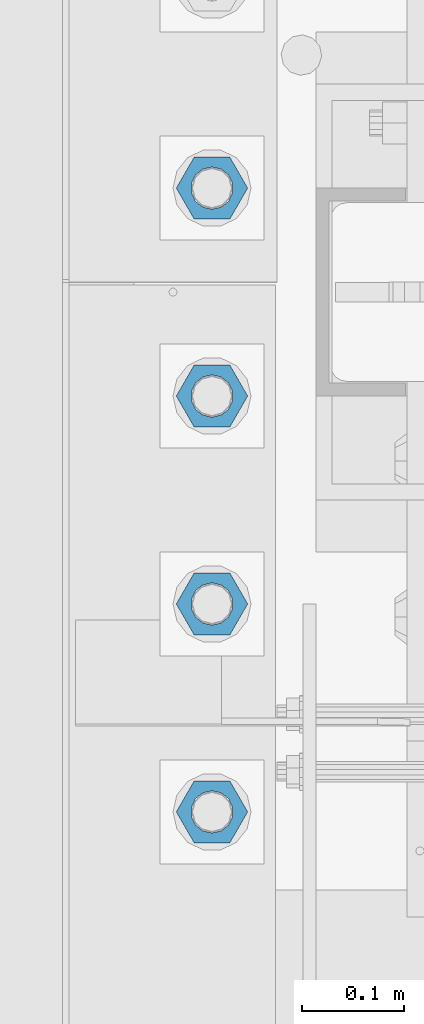
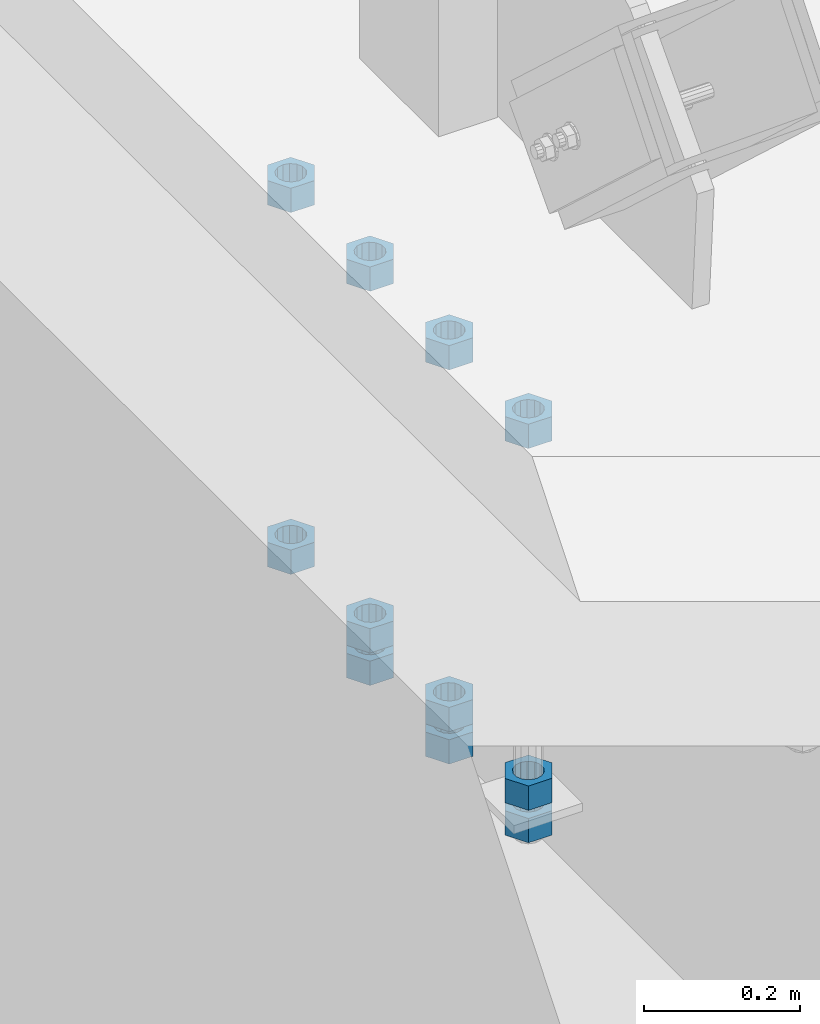
# One storey, part 984 of 1763: 11 columns, 1 element without a shape of its own.
"""IFC2X3 building model written with IfcOpenShell, lengths in millimetres."""

from ifc_helpers import new_model, si_unit, frame, origin_with_axes, place, context, subcontext, project, spatial, faceted_brep, material, type_object, element, aggregate, save


model = new_model("IFC2X3")

# Units and contexts
model_context = context("Model", 3, precision=1e-05, world=origin_with_axes())
body_context = subcontext(model_context, "Body", "Model", "MODEL_VIEW")
ifc_project = project(units=[si_unit("LENGTHUNIT", "METRE", prefix="MILLI"), si_unit("AREAUNIT", "SQUARE_METRE"), si_unit("VOLUMEUNIT", "CUBIC_METRE"), si_unit("MASSUNIT", "GRAM", prefix="KILO"), si_unit("TIMEUNIT", "SECOND"), si_unit("PLANEANGLEUNIT", "RADIAN"), si_unit("SOLIDANGLEUNIT", "STERADIAN"), si_unit("THERMODYNAMICTEMPERATUREUNIT", "DEGREE_CELSIUS"), si_unit("LUMINOUSINTENSITYUNIT", "LUMEN")], contexts=[model_context])

# Site, building, storey
site_placement = place(None, origin_with_axes())
site = spatial("IfcSite", under=ifc_project, at=site_placement, CompositionType="ELEMENT")
building_placement = place(site_placement, origin_with_axes())
building = spatial("IfcBuilding", under=site, at=building_placement, Name="Undefined", CompositionType="ELEMENT")
storey_placement = place(building_placement, origin_with_axes())
storey = spatial("IfcBuildingStorey", under=building, at=storey_placement, Name="Undefined", CompositionType="ELEMENT", Elevation=0.0)

# Assembly, columns
assembly_placement = place(storey_placement, origin_with_axes())
assembly = element("IfcElementAssembly", 1, at=assembly_placement, inside=storey, Name="TEMPLATE", AssemblyPlace="NOTDEFINED", PredefinedType="RIGID_FRAME")
ifc_material = material(Name="STEEL/A563")
column_type = type_object("IfcColumnType", Name="1-1/2_HEAVY_HEX_NUT", PredefinedType="NOTDEFINED")
column_1_placement = place(assembly_placement, frame((-87578.6372736983, -50.7999999999992, 5189.5375), z_axis=(0.0, -1.0, 0.0), x_axis=(0.0, 0.0, -1.0)))
column_1 = element("IfcColumn", 2, at=column_1_placement, type_object=column_type, material=ifc_material, Name="NUT", ObjectType="1-1/2_HEAVY_HEX_NUT", context=body_context, shape_type="Brep", body=[
    faceted_brep([(0.0, -34.9199981689453, 0.0), (0.0, -17.4599990844727, -30.25), (38.1000000000004, -17.4599990844727, -30.25), (38.1000000000004, -34.9199981689453, 0.0), (0.0, 17.4599990844727, -30.25), (38.1000000000004, 17.4599990844727, -30.25), (0.0, 34.9199981689453, 0.0), (38.1000000000004, 34.9199981689453, 0.0), (0.0, 17.4599990844727, 30.25), (38.1000000000004, 17.4599990844727, 30.25), (0.0, -17.4599990844727, 30.25), (38.1000000000004, -17.4599990844727, 30.25), (0.0, 0.0, 20.6399993896484), (0.0, 8.95536011056538, 18.5959968835978), (38.1000000000004, 8.95536011056538, 18.5959968835978), (38.1000000000004, 0.0, 20.6399993896484), (0.0, 16.1370013209453, 12.8688291298167), (38.1000000000004, 16.1370013209453, 12.8688291298167), (0.0, 20.1225115123816, 4.59283194104137), (38.1000000000004, 20.1225115123816, 4.59283194104137), (0.0, 20.1225115123816, -4.59283194104319), (38.1000000000004, 20.1225115123816, -4.59283194104319), (0.0, 16.1370013209453, -12.8688291298167), (38.1000000000004, 16.1370013209453, -12.8688291298167), (0.0, 8.95536011056538, -18.5959968835978), (38.1000000000004, 8.95536011056538, -18.5959968835978), (0.0, 0.0, -20.6399993896484), (38.1000000000004, 0.0, -20.6399993896484), (0.0, -8.95536011056538, -18.5959968835978), (38.1000000000004, -8.95536011056538, -18.5959968835978), (0.0, -16.1370013209453, -12.8688291298167), (38.1000000000004, -16.1370013209453, -12.8688291298167), (0.0, -20.1225115123816, -4.59283194104137), (38.1000000000004, -20.1225115123816, -4.59283194104137), (0.0, -20.1225115123816, 4.59283194104319), (38.1000000000004, -20.1225115123816, 4.59283194104319), (0.0, -16.1370013209453, 12.8688291298167), (38.1000000000004, -16.1370013209453, 12.8688291298167), (0.0, -8.95536011056538, 18.5959968835978), (38.1000000000004, -8.95536011056538, 18.5959968835978)], [[[0, 1, 2, 3]], [[1, 4, 5, 2]], [[4, 6, 7, 5]], [[6, 8, 9, 7]], [[8, 10, 11, 9]], [[10, 0, 3, 11]], [[12, 13, 14, 15]], [[13, 16, 17, 14]], [[16, 18, 19, 17]], [[18, 20, 21, 19]], [[20, 22, 23, 21]], [[22, 24, 25, 23]], [[24, 26, 27, 25]], [[26, 28, 29, 27]], [[28, 30, 31, 29]], [[30, 32, 33, 31]], [[32, 34, 35, 33]], [[34, 36, 37, 35]], [[36, 38, 39, 37]], [[38, 12, 15, 39]], [[5, 7, 9, 11, 3, 2], [17, 19, 21, 23, 25, 27, 29, 31, 33, 35, 37, 39, 15, 14]], [[10, 8, 6, 4, 1, 0], [38, 36, 34, 32, 30, 28, 26, 24, 22, 20, 18, 16, 13, 12]]]),
])
column_2_placement = place(assembly_placement, frame((-87578.6372736983, -50.7999999999992, 4622.8), z_axis=(0.0, -1.0, 0.0), x_axis=(0.0, 0.0, -1.0)))
column_2 = element("IfcColumn", 3, at=column_2_placement, type_object=column_type, material=ifc_material, Name="NUT", ObjectType="1-1/2_HEAVY_HEX_NUT", context=body_context, shape_type="Brep", body=[
    faceted_brep([(0.0, -34.9199981689453, 0.0), (0.0, -17.4599990844727, -30.25), (38.1000000000004, -17.4599990844727, -30.25), (38.1000000000004, -34.9199981689453, 0.0), (0.0, 17.4599990844727, -30.25), (38.1000000000004, 17.4599990844727, -30.25), (0.0, 34.9199981689453, 0.0), (38.1000000000004, 34.9199981689453, 0.0), (0.0, 17.4599990844727, 30.25), (38.1000000000004, 17.4599990844727, 30.25), (0.0, -17.4599990844727, 30.25), (38.1000000000004, -17.4599990844727, 30.25), (0.0, 0.0, 20.6399993896484), (0.0, 8.95536011056538, 18.5959968835978), (38.1000000000004, 8.95536011056538, 18.5959968835978), (38.1000000000004, 0.0, 20.6399993896484), (0.0, 16.1370013209453, 12.8688291298167), (38.1000000000004, 16.1370013209453, 12.8688291298167), (0.0, 20.1225115123816, 4.59283194104137), (38.1000000000004, 20.1225115123816, 4.59283194104137), (0.0, 20.1225115123816, -4.59283194104319), (38.1000000000004, 20.1225115123816, -4.59283194104319), (0.0, 16.1370013209453, -12.8688291298167), (38.1000000000004, 16.1370013209453, -12.8688291298167), (0.0, 8.95536011056538, -18.5959968835978), (38.1000000000004, 8.95536011056538, -18.5959968835978), (0.0, 0.0, -20.6399993896484), (38.1000000000004, 0.0, -20.6399993896484), (0.0, -8.95536011056538, -18.5959968835978), (38.1000000000004, -8.95536011056538, -18.5959968835978), (0.0, -16.1370013209453, -12.8688291298167), (38.1000000000004, -16.1370013209453, -12.8688291298167), (0.0, -20.1225115123816, -4.59283194104137), (38.1000000000004, -20.1225115123816, -4.59283194104137), (0.0, -20.1225115123816, 4.59283194104319), (38.1000000000004, -20.1225115123816, 4.59283194104319), (0.0, -16.1370013209453, 12.8688291298167), (38.1000000000004, -16.1370013209453, 12.8688291298167), (0.0, -8.95536011056538, 18.5959968835978), (38.1000000000004, -8.95536011056538, 18.5959968835978)], [[[0, 1, 2, 3]], [[1, 4, 5, 2]], [[4, 6, 7, 5]], [[6, 8, 9, 7]], [[8, 10, 11, 9]], [[10, 0, 3, 11]], [[12, 13, 14, 15]], [[13, 16, 17, 14]], [[16, 18, 19, 17]], [[18, 20, 21, 19]], [[20, 22, 23, 21]], [[22, 24, 25, 23]], [[24, 26, 27, 25]], [[26, 28, 29, 27]], [[28, 30, 31, 29]], [[30, 32, 33, 31]], [[32, 34, 35, 33]], [[34, 36, 37, 35]], [[36, 38, 39, 37]], [[38, 12, 15, 39]], [[5, 7, 9, 11, 3, 2], [17, 19, 21, 23, 25, 27, 29, 31, 33, 35, 37, 39, 15, 14]], [[10, 8, 6, 4, 1, 0], [38, 36, 34, 32, 30, 28, 26, 24, 22, 20, 18, 16, 13, 12]]]),
])
column_3_placement = place(assembly_placement, frame((-87578.6372736983, -50.7999999999992, 4572.0), z_axis=(0.0, -1.0, 0.0), x_axis=(0.0, 0.0, -1.0)))
column_3 = element("IfcColumn", 4, at=column_3_placement, type_object=column_type, material=ifc_material, Name="NUT", ObjectType="1-1/2_HEAVY_HEX_NUT", context=body_context, shape_type="Brep", body=[
    faceted_brep([(0.0, -34.9199981689453, 0.0), (0.0, -17.4599990844727, -30.25), (38.1000000000004, -17.4599990844727, -30.25), (38.1000000000004, -34.9199981689453, 0.0), (0.0, 17.4599990844727, -30.25), (38.1000000000004, 17.4599990844727, -30.25), (0.0, 34.9199981689453, 0.0), (38.1000000000004, 34.9199981689453, 0.0), (0.0, 17.4599990844727, 30.25), (38.1000000000004, 17.4599990844727, 30.25), (0.0, -17.4599990844727, 30.25), (38.1000000000004, -17.4599990844727, 30.25), (0.0, 0.0, 20.6399993896484), (0.0, 8.95536011056538, 18.5959968835978), (38.1000000000004, 8.95536011056538, 18.5959968835978), (38.1000000000004, 0.0, 20.6399993896484), (0.0, 16.1370013209453, 12.8688291298167), (38.1000000000004, 16.1370013209453, 12.8688291298167), (0.0, 20.1225115123816, 4.59283194104137), (38.1000000000004, 20.1225115123816, 4.59283194104137), (0.0, 20.1225115123816, -4.59283194104319), (38.1000000000004, 20.1225115123816, -4.59283194104319), (0.0, 16.1370013209453, -12.8688291298167), (38.1000000000004, 16.1370013209453, -12.8688291298167), (0.0, 8.95536011056538, -18.5959968835978), (38.1000000000004, 8.95536011056538, -18.5959968835978), (0.0, 0.0, -20.6399993896484), (38.1000000000004, 0.0, -20.6399993896484), (0.0, -8.95536011056538, -18.5959968835978), (38.1000000000004, -8.95536011056538, -18.5959968835978), (0.0, -16.1370013209453, -12.8688291298167), (38.1000000000004, -16.1370013209453, -12.8688291298167), (0.0, -20.1225115123816, -4.59283194104137), (38.1000000000004, -20.1225115123816, -4.59283194104137), (0.0, -20.1225115123816, 4.59283194104319), (38.1000000000004, -20.1225115123816, 4.59283194104319), (0.0, -16.1370013209453, 12.8688291298167), (38.1000000000004, -16.1370013209453, 12.8688291298167), (0.0, -8.95536011056538, 18.5959968835978), (38.1000000000004, -8.95536011056538, 18.5959968835978)], [[[0, 1, 2, 3]], [[1, 4, 5, 2]], [[4, 6, 7, 5]], [[6, 8, 9, 7]], [[8, 10, 11, 9]], [[10, 0, 3, 11]], [[12, 13, 14, 15]], [[13, 16, 17, 14]], [[16, 18, 19, 17]], [[18, 20, 21, 19]], [[20, 22, 23, 21]], [[22, 24, 25, 23]], [[24, 26, 27, 25]], [[26, 28, 29, 27]], [[28, 30, 31, 29]], [[30, 32, 33, 31]], [[32, 34, 35, 33]], [[34, 36, 37, 35]], [[36, 38, 39, 37]], [[38, 12, 15, 39]], [[5, 7, 9, 11, 3, 2], [17, 19, 21, 23, 25, 27, 29, 31, 33, 35, 37, 39, 15, 14]], [[10, 8, 6, 4, 1, 0], [38, 36, 34, 32, 30, 28, 26, 24, 22, 20, 18, 16, 13, 12]]]),
])
column_4_placement = place(assembly_placement, frame((-87578.6372736983, 152.400000000001, 5189.5375), z_axis=(0.0, -1.0, 0.0), x_axis=(0.0, 0.0, -1.0)))
column_4 = element("IfcColumn", 5, at=column_4_placement, type_object=column_type, material=ifc_material, Name="NUT", ObjectType="1-1/2_HEAVY_HEX_NUT", context=body_context, shape_type="Brep", body=[
    faceted_brep([(0.0, -34.9199981689453, 0.0), (0.0, -17.4599990844727, -30.25), (38.1000000000004, -17.4599990844727, -30.25), (38.1000000000004, -34.9199981689453, 0.0), (0.0, 17.4599990844727, -30.25), (38.1000000000004, 17.4599990844727, -30.25), (0.0, 34.9199981689453, 0.0), (38.1000000000004, 34.9199981689453, 0.0), (0.0, 17.4599990844727, 30.25), (38.1000000000004, 17.4599990844727, 30.25), (0.0, -17.4599990844727, 30.25), (38.1000000000004, -17.4599990844727, 30.25), (0.0, 0.0, 20.6399993896484), (0.0, 8.95536011056538, 18.5959968835978), (38.1000000000004, 8.95536011056538, 18.5959968835978), (38.1000000000004, 0.0, 20.6399993896484), (0.0, 16.1370013209453, 12.8688291298167), (38.1000000000004, 16.1370013209453, 12.8688291298167), (0.0, 20.1225115123816, 4.59283194104137), (38.1000000000004, 20.1225115123816, 4.59283194104137), (0.0, 20.1225115123816, -4.59283194104319), (38.1000000000004, 20.1225115123816, -4.59283194104319), (0.0, 16.1370013209453, -12.8688291298167), (38.1000000000004, 16.1370013209453, -12.8688291298167), (0.0, 8.95536011056538, -18.5959968835978), (38.1000000000004, 8.95536011056538, -18.5959968835978), (0.0, 0.0, -20.6399993896484), (38.1000000000004, 0.0, -20.6399993896484), (0.0, -8.95536011056538, -18.5959968835978), (38.1000000000004, -8.95536011056538, -18.5959968835978), (0.0, -16.1370013209453, -12.8688291298167), (38.1000000000004, -16.1370013209453, -12.8688291298167), (0.0, -20.1225115123816, -4.59283194104137), (38.1000000000004, -20.1225115123816, -4.59283194104137), (0.0, -20.1225115123816, 4.59283194104319), (38.1000000000004, -20.1225115123816, 4.59283194104319), (0.0, -16.1370013209453, 12.8688291298167), (38.1000000000004, -16.1370013209453, 12.8688291298167), (0.0, -8.95536011056538, 18.5959968835978), (38.1000000000004, -8.95536011056538, 18.5959968835978)], [[[0, 1, 2, 3]], [[1, 4, 5, 2]], [[4, 6, 7, 5]], [[6, 8, 9, 7]], [[8, 10, 11, 9]], [[10, 0, 3, 11]], [[12, 13, 14, 15]], [[13, 16, 17, 14]], [[16, 18, 19, 17]], [[18, 20, 21, 19]], [[20, 22, 23, 21]], [[22, 24, 25, 23]], [[24, 26, 27, 25]], [[26, 28, 29, 27]], [[28, 30, 31, 29]], [[30, 32, 33, 31]], [[32, 34, 35, 33]], [[34, 36, 37, 35]], [[36, 38, 39, 37]], [[38, 12, 15, 39]], [[5, 7, 9, 11, 3, 2], [17, 19, 21, 23, 25, 27, 29, 31, 33, 35, 37, 39, 15, 14]], [[10, 8, 6, 4, 1, 0], [38, 36, 34, 32, 30, 28, 26, 24, 22, 20, 18, 16, 13, 12]]]),
])
column_5_placement = place(assembly_placement, frame((-87578.6372736983, 152.400000000001, 4622.8), z_axis=(0.0, -1.0, 0.0), x_axis=(0.0, 0.0, -1.0)))
column_5 = element("IfcColumn", 6, at=column_5_placement, type_object=column_type, material=ifc_material, Name="NUT", ObjectType="1-1/2_HEAVY_HEX_NUT", context=body_context, shape_type="Brep", body=[
    faceted_brep([(0.0, -34.9199981689453, 0.0), (0.0, -17.4599990844727, -30.25), (38.1000000000004, -17.4599990844727, -30.25), (38.1000000000004, -34.9199981689453, 0.0), (0.0, 17.4599990844727, -30.25), (38.1000000000004, 17.4599990844727, -30.25), (0.0, 34.9199981689453, 0.0), (38.1000000000004, 34.9199981689453, 0.0), (0.0, 17.4599990844727, 30.25), (38.1000000000004, 17.4599990844727, 30.25), (0.0, -17.4599990844727, 30.25), (38.1000000000004, -17.4599990844727, 30.25), (0.0, 0.0, 20.6399993896484), (0.0, 8.95536011056538, 18.5959968835978), (38.1000000000004, 8.95536011056538, 18.5959968835978), (38.1000000000004, 0.0, 20.6399993896484), (0.0, 16.1370013209453, 12.8688291298167), (38.1000000000004, 16.1370013209453, 12.8688291298167), (0.0, 20.1225115123816, 4.59283194104137), (38.1000000000004, 20.1225115123816, 4.59283194104137), (0.0, 20.1225115123816, -4.59283194104319), (38.1000000000004, 20.1225115123816, -4.59283194104319), (0.0, 16.1370013209453, -12.8688291298167), (38.1000000000004, 16.1370013209453, -12.8688291298167), (0.0, 8.95536011056538, -18.5959968835978), (38.1000000000004, 8.95536011056538, -18.5959968835978), (0.0, 0.0, -20.6399993896484), (38.1000000000004, 0.0, -20.6399993896484), (0.0, -8.95536011056538, -18.5959968835978), (38.1000000000004, -8.95536011056538, -18.5959968835978), (0.0, -16.1370013209453, -12.8688291298167), (38.1000000000004, -16.1370013209453, -12.8688291298167), (0.0, -20.1225115123816, -4.59283194104137), (38.1000000000004, -20.1225115123816, -4.59283194104137), (0.0, -20.1225115123816, 4.59283194104319), (38.1000000000004, -20.1225115123816, 4.59283194104319), (0.0, -16.1370013209453, 12.8688291298167), (38.1000000000004, -16.1370013209453, 12.8688291298167), (0.0, -8.95536011056538, 18.5959968835978), (38.1000000000004, -8.95536011056538, 18.5959968835978)], [[[0, 1, 2, 3]], [[1, 4, 5, 2]], [[4, 6, 7, 5]], [[6, 8, 9, 7]], [[8, 10, 11, 9]], [[10, 0, 3, 11]], [[12, 13, 14, 15]], [[13, 16, 17, 14]], [[16, 18, 19, 17]], [[18, 20, 21, 19]], [[20, 22, 23, 21]], [[22, 24, 25, 23]], [[24, 26, 27, 25]], [[26, 28, 29, 27]], [[28, 30, 31, 29]], [[30, 32, 33, 31]], [[32, 34, 35, 33]], [[34, 36, 37, 35]], [[36, 38, 39, 37]], [[38, 12, 15, 39]], [[5, 7, 9, 11, 3, 2], [17, 19, 21, 23, 25, 27, 29, 31, 33, 35, 37, 39, 15, 14]], [[10, 8, 6, 4, 1, 0], [38, 36, 34, 32, 30, 28, 26, 24, 22, 20, 18, 16, 13, 12]]]),
])
column_6_placement = place(assembly_placement, frame((-87578.6372736983, 152.400000000001, 4572.0), z_axis=(0.0, -1.0, 0.0), x_axis=(0.0, 0.0, -1.0)))
column_6 = element("IfcColumn", 7, at=column_6_placement, type_object=column_type, material=ifc_material, Name="NUT", ObjectType="1-1/2_HEAVY_HEX_NUT", context=body_context, shape_type="Brep", body=[
    faceted_brep([(0.0, -34.9199981689453, 0.0), (0.0, -17.4599990844727, -30.25), (38.1000000000004, -17.4599990844727, -30.25), (38.1000000000004, -34.9199981689453, 0.0), (0.0, 17.4599990844727, -30.25), (38.1000000000004, 17.4599990844727, -30.25), (0.0, 34.9199981689453, 0.0), (38.1000000000004, 34.9199981689453, 0.0), (0.0, 17.4599990844727, 30.25), (38.1000000000004, 17.4599990844727, 30.25), (0.0, -17.4599990844727, 30.25), (38.1000000000004, -17.4599990844727, 30.25), (0.0, 0.0, 20.6399993896484), (0.0, 8.95536011056538, 18.5959968835978), (38.1000000000004, 8.95536011056538, 18.5959968835978), (38.1000000000004, 0.0, 20.6399993896484), (0.0, 16.1370013209453, 12.8688291298167), (38.1000000000004, 16.1370013209453, 12.8688291298167), (0.0, 20.1225115123816, 4.59283194104137), (38.1000000000004, 20.1225115123816, 4.59283194104137), (0.0, 20.1225115123816, -4.59283194104319), (38.1000000000004, 20.1225115123816, -4.59283194104319), (0.0, 16.1370013209453, -12.8688291298167), (38.1000000000004, 16.1370013209453, -12.8688291298167), (0.0, 8.95536011056538, -18.5959968835978), (38.1000000000004, 8.95536011056538, -18.5959968835978), (0.0, 0.0, -20.6399993896484), (38.1000000000004, 0.0, -20.6399993896484), (0.0, -8.95536011056538, -18.5959968835978), (38.1000000000004, -8.95536011056538, -18.5959968835978), (0.0, -16.1370013209453, -12.8688291298167), (38.1000000000004, -16.1370013209453, -12.8688291298167), (0.0, -20.1225115123816, -4.59283194104137), (38.1000000000004, -20.1225115123816, -4.59283194104137), (0.0, -20.1225115123816, 4.59283194104319), (38.1000000000004, -20.1225115123816, 4.59283194104319), (0.0, -16.1370013209453, 12.8688291298167), (38.1000000000004, -16.1370013209453, 12.8688291298167), (0.0, -8.95536011056538, 18.5959968835978), (38.1000000000004, -8.95536011056538, 18.5959968835978)], [[[0, 1, 2, 3]], [[1, 4, 5, 2]], [[4, 6, 7, 5]], [[6, 8, 9, 7]], [[8, 10, 11, 9]], [[10, 0, 3, 11]], [[12, 13, 14, 15]], [[13, 16, 17, 14]], [[16, 18, 19, 17]], [[18, 20, 21, 19]], [[20, 22, 23, 21]], [[22, 24, 25, 23]], [[24, 26, 27, 25]], [[26, 28, 29, 27]], [[28, 30, 31, 29]], [[30, 32, 33, 31]], [[32, 34, 35, 33]], [[34, 36, 37, 35]], [[36, 38, 39, 37]], [[38, 12, 15, 39]], [[5, 7, 9, 11, 3, 2], [17, 19, 21, 23, 25, 27, 29, 31, 33, 35, 37, 39, 15, 14]], [[10, 8, 6, 4, 1, 0], [38, 36, 34, 32, 30, 28, 26, 24, 22, 20, 18, 16, 13, 12]]]),
])
column_7_placement = place(assembly_placement, frame((-87578.6372736983, 355.600000000001, 5189.5375), z_axis=(0.0, -1.0, 0.0), x_axis=(0.0, 0.0, -1.0)))
column_7 = element("IfcColumn", 8, at=column_7_placement, type_object=column_type, material=ifc_material, Name="NUT", ObjectType="1-1/2_HEAVY_HEX_NUT", context=body_context, shape_type="Brep", body=[
    faceted_brep([(0.0, -34.9199981689453, 0.0), (0.0, -17.4599990844727, -30.25), (38.1000000000004, -17.4599990844727, -30.25), (38.1000000000004, -34.9199981689453, 0.0), (0.0, 17.4599990844727, -30.25), (38.1000000000004, 17.4599990844727, -30.25), (0.0, 34.9199981689453, 0.0), (38.1000000000004, 34.9199981689453, 0.0), (0.0, 17.4599990844727, 30.25), (38.1000000000004, 17.4599990844727, 30.25), (0.0, -17.4599990844727, 30.25), (38.1000000000004, -17.4599990844727, 30.25), (0.0, 0.0, 20.6399993896484), (0.0, 8.95536011056538, 18.5959968835978), (38.1000000000004, 8.95536011056538, 18.5959968835978), (38.1000000000004, 0.0, 20.6399993896484), (0.0, 16.1370013209453, 12.8688291298167), (38.1000000000004, 16.1370013209453, 12.8688291298167), (0.0, 20.1225115123816, 4.59283194104137), (38.1000000000004, 20.1225115123816, 4.59283194104137), (0.0, 20.1225115123816, -4.59283194104319), (38.1000000000004, 20.1225115123816, -4.59283194104319), (0.0, 16.1370013209453, -12.8688291298167), (38.1000000000004, 16.1370013209453, -12.8688291298167), (0.0, 8.95536011056538, -18.5959968835978), (38.1000000000004, 8.95536011056538, -18.5959968835978), (0.0, 0.0, -20.6399993896484), (38.1000000000004, 0.0, -20.6399993896484), (0.0, -8.95536011056538, -18.5959968835978), (38.1000000000004, -8.95536011056538, -18.5959968835978), (0.0, -16.1370013209453, -12.8688291298167), (38.1000000000004, -16.1370013209453, -12.8688291298167), (0.0, -20.1225115123816, -4.59283194104137), (38.1000000000004, -20.1225115123816, -4.59283194104137), (0.0, -20.1225115123816, 4.59283194104319), (38.1000000000004, -20.1225115123816, 4.59283194104319), (0.0, -16.1370013209453, 12.8688291298167), (38.1000000000004, -16.1370013209453, 12.8688291298167), (0.0, -8.95536011056538, 18.5959968835978), (38.1000000000004, -8.95536011056538, 18.5959968835978)], [[[0, 1, 2, 3]], [[1, 4, 5, 2]], [[4, 6, 7, 5]], [[6, 8, 9, 7]], [[8, 10, 11, 9]], [[10, 0, 3, 11]], [[12, 13, 14, 15]], [[13, 16, 17, 14]], [[16, 18, 19, 17]], [[18, 20, 21, 19]], [[20, 22, 23, 21]], [[22, 24, 25, 23]], [[24, 26, 27, 25]], [[26, 28, 29, 27]], [[28, 30, 31, 29]], [[30, 32, 33, 31]], [[32, 34, 35, 33]], [[34, 36, 37, 35]], [[36, 38, 39, 37]], [[38, 12, 15, 39]], [[5, 7, 9, 11, 3, 2], [17, 19, 21, 23, 25, 27, 29, 31, 33, 35, 37, 39, 15, 14]], [[10, 8, 6, 4, 1, 0], [38, 36, 34, 32, 30, 28, 26, 24, 22, 20, 18, 16, 13, 12]]]),
])
column_8_placement = place(assembly_placement, frame((-87578.6372736983, 355.600000000001, 4622.8), z_axis=(0.0, -1.0, 0.0), x_axis=(0.0, 0.0, -1.0)))
column_8 = element("IfcColumn", 9, at=column_8_placement, type_object=column_type, material=ifc_material, Name="NUT", ObjectType="1-1/2_HEAVY_HEX_NUT", context=body_context, shape_type="Brep", body=[
    faceted_brep([(0.0, -34.9199981689453, 0.0), (0.0, -17.4599990844727, -30.25), (38.1000000000004, -17.4599990844727, -30.25), (38.1000000000004, -34.9199981689453, 0.0), (0.0, 17.4599990844727, -30.25), (38.1000000000004, 17.4599990844727, -30.25), (0.0, 34.9199981689453, 0.0), (38.1000000000004, 34.9199981689453, 0.0), (0.0, 17.4599990844727, 30.25), (38.1000000000004, 17.4599990844727, 30.25), (0.0, -17.4599990844727, 30.25), (38.1000000000004, -17.4599990844727, 30.25), (0.0, 0.0, 20.6399993896484), (0.0, 8.95536011056538, 18.5959968835978), (38.1000000000004, 8.95536011056538, 18.5959968835978), (38.1000000000004, 0.0, 20.6399993896484), (0.0, 16.1370013209453, 12.8688291298167), (38.1000000000004, 16.1370013209453, 12.8688291298167), (0.0, 20.1225115123816, 4.59283194104137), (38.1000000000004, 20.1225115123816, 4.59283194104137), (0.0, 20.1225115123816, -4.59283194104319), (38.1000000000004, 20.1225115123816, -4.59283194104319), (0.0, 16.1370013209453, -12.8688291298167), (38.1000000000004, 16.1370013209453, -12.8688291298167), (0.0, 8.95536011056538, -18.5959968835978), (38.1000000000004, 8.95536011056538, -18.5959968835978), (0.0, 0.0, -20.6399993896484), (38.1000000000004, 0.0, -20.6399993896484), (0.0, -8.95536011056538, -18.5959968835978), (38.1000000000004, -8.95536011056538, -18.5959968835978), (0.0, -16.1370013209453, -12.8688291298167), (38.1000000000004, -16.1370013209453, -12.8688291298167), (0.0, -20.1225115123816, -4.59283194104137), (38.1000000000004, -20.1225115123816, -4.59283194104137), (0.0, -20.1225115123816, 4.59283194104319), (38.1000000000004, -20.1225115123816, 4.59283194104319), (0.0, -16.1370013209453, 12.8688291298167), (38.1000000000004, -16.1370013209453, 12.8688291298167), (0.0, -8.95536011056538, 18.5959968835978), (38.1000000000004, -8.95536011056538, 18.5959968835978)], [[[0, 1, 2, 3]], [[1, 4, 5, 2]], [[4, 6, 7, 5]], [[6, 8, 9, 7]], [[8, 10, 11, 9]], [[10, 0, 3, 11]], [[12, 13, 14, 15]], [[13, 16, 17, 14]], [[16, 18, 19, 17]], [[18, 20, 21, 19]], [[20, 22, 23, 21]], [[22, 24, 25, 23]], [[24, 26, 27, 25]], [[26, 28, 29, 27]], [[28, 30, 31, 29]], [[30, 32, 33, 31]], [[32, 34, 35, 33]], [[34, 36, 37, 35]], [[36, 38, 39, 37]], [[38, 12, 15, 39]], [[5, 7, 9, 11, 3, 2], [17, 19, 21, 23, 25, 27, 29, 31, 33, 35, 37, 39, 15, 14]], [[10, 8, 6, 4, 1, 0], [38, 36, 34, 32, 30, 28, 26, 24, 22, 20, 18, 16, 13, 12]]]),
])
column_9_placement = place(assembly_placement, frame((-87578.6372736983, 355.600000000001, 4572.0), z_axis=(0.0, -1.0, 0.0), x_axis=(0.0, 0.0, -1.0)))
column_9 = element("IfcColumn", 10, at=column_9_placement, type_object=column_type, material=ifc_material, Name="NUT", ObjectType="1-1/2_HEAVY_HEX_NUT", context=body_context, shape_type="Brep", body=[
    faceted_brep([(0.0, -34.9199981689453, 0.0), (0.0, -17.4599990844727, -30.25), (38.1000000000004, -17.4599990844727, -30.25), (38.1000000000004, -34.9199981689453, 0.0), (0.0, 17.4599990844727, -30.25), (38.1000000000004, 17.4599990844727, -30.25), (0.0, 34.9199981689453, 0.0), (38.1000000000004, 34.9199981689453, 0.0), (0.0, 17.4599990844727, 30.25), (38.1000000000004, 17.4599990844727, 30.25), (0.0, -17.4599990844727, 30.25), (38.1000000000004, -17.4599990844727, 30.25), (0.0, 0.0, 20.6399993896484), (0.0, 8.95536011056538, 18.5959968835978), (38.1000000000004, 8.95536011056538, 18.5959968835978), (38.1000000000004, 0.0, 20.6399993896484), (0.0, 16.1370013209453, 12.8688291298167), (38.1000000000004, 16.1370013209453, 12.8688291298167), (0.0, 20.1225115123816, 4.59283194104137), (38.1000000000004, 20.1225115123816, 4.59283194104137), (0.0, 20.1225115123816, -4.59283194104319), (38.1000000000004, 20.1225115123816, -4.59283194104319), (0.0, 16.1370013209453, -12.8688291298167), (38.1000000000004, 16.1370013209453, -12.8688291298167), (0.0, 8.95536011056538, -18.5959968835978), (38.1000000000004, 8.95536011056538, -18.5959968835978), (0.0, 0.0, -20.6399993896484), (38.1000000000004, 0.0, -20.6399993896484), (0.0, -8.95536011056538, -18.5959968835978), (38.1000000000004, -8.95536011056538, -18.5959968835978), (0.0, -16.1370013209453, -12.8688291298167), (38.1000000000004, -16.1370013209453, -12.8688291298167), (0.0, -20.1225115123816, -4.59283194104137), (38.1000000000004, -20.1225115123816, -4.59283194104137), (0.0, -20.1225115123816, 4.59283194104319), (38.1000000000004, -20.1225115123816, 4.59283194104319), (0.0, -16.1370013209453, 12.8688291298167), (38.1000000000004, -16.1370013209453, 12.8688291298167), (0.0, -8.95536011056538, 18.5959968835978), (38.1000000000004, -8.95536011056538, 18.5959968835978)], [[[0, 1, 2, 3]], [[1, 4, 5, 2]], [[4, 6, 7, 5]], [[6, 8, 9, 7]], [[8, 10, 11, 9]], [[10, 0, 3, 11]], [[12, 13, 14, 15]], [[13, 16, 17, 14]], [[16, 18, 19, 17]], [[18, 20, 21, 19]], [[20, 22, 23, 21]], [[22, 24, 25, 23]], [[24, 26, 27, 25]], [[26, 28, 29, 27]], [[28, 30, 31, 29]], [[30, 32, 33, 31]], [[32, 34, 35, 33]], [[34, 36, 37, 35]], [[36, 38, 39, 37]], [[38, 12, 15, 39]], [[5, 7, 9, 11, 3, 2], [17, 19, 21, 23, 25, 27, 29, 31, 33, 35, 37, 39, 15, 14]], [[10, 8, 6, 4, 1, 0], [38, 36, 34, 32, 30, 28, 26, 24, 22, 20, 18, 16, 13, 12]]]),
])
column_10_placement = place(assembly_placement, frame((-87578.6372736983, 558.800000000001, 5189.5375), z_axis=(0.0, -1.0, 0.0), x_axis=(0.0, 0.0, -1.0)))
column_10 = element("IfcColumn", 11, at=column_10_placement, type_object=column_type, material=ifc_material, Name="NUT", ObjectType="1-1/2_HEAVY_HEX_NUT", context=body_context, shape_type="Brep", body=[
    faceted_brep([(0.0, -34.9199981689453, 0.0), (0.0, -17.4599990844727, -30.25), (38.1000000000004, -17.4599990844727, -30.25), (38.1000000000004, -34.9199981689453, 0.0), (0.0, 17.4599990844727, -30.25), (38.1000000000004, 17.4599990844727, -30.25), (0.0, 34.9199981689453, 0.0), (38.1000000000004, 34.9199981689453, 0.0), (0.0, 17.4599990844727, 30.25), (38.1000000000004, 17.4599990844727, 30.25), (0.0, -17.4599990844727, 30.25), (38.1000000000004, -17.4599990844727, 30.25), (0.0, 0.0, 20.6399993896484), (0.0, 8.95536011056538, 18.5959968835978), (38.1000000000004, 8.95536011056538, 18.5959968835978), (38.1000000000004, 0.0, 20.6399993896484), (0.0, 16.1370013209453, 12.8688291298167), (38.1000000000004, 16.1370013209453, 12.8688291298167), (0.0, 20.1225115123816, 4.59283194104137), (38.1000000000004, 20.1225115123816, 4.59283194104137), (0.0, 20.1225115123816, -4.59283194104319), (38.1000000000004, 20.1225115123816, -4.59283194104319), (0.0, 16.1370013209453, -12.8688291298167), (38.1000000000004, 16.1370013209453, -12.8688291298167), (0.0, 8.95536011056538, -18.5959968835978), (38.1000000000004, 8.95536011056538, -18.5959968835978), (0.0, 0.0, -20.6399993896484), (38.1000000000004, 0.0, -20.6399993896484), (0.0, -8.95536011056538, -18.5959968835978), (38.1000000000004, -8.95536011056538, -18.5959968835978), (0.0, -16.1370013209453, -12.8688291298167), (38.1000000000004, -16.1370013209453, -12.8688291298167), (0.0, -20.1225115123816, -4.59283194104137), (38.1000000000004, -20.1225115123816, -4.59283194104137), (0.0, -20.1225115123816, 4.59283194104319), (38.1000000000004, -20.1225115123816, 4.59283194104319), (0.0, -16.1370013209453, 12.8688291298167), (38.1000000000004, -16.1370013209453, 12.8688291298167), (0.0, -8.95536011056538, 18.5959968835978), (38.1000000000004, -8.95536011056538, 18.5959968835978)], [[[0, 1, 2, 3]], [[1, 4, 5, 2]], [[4, 6, 7, 5]], [[6, 8, 9, 7]], [[8, 10, 11, 9]], [[10, 0, 3, 11]], [[12, 13, 14, 15]], [[13, 16, 17, 14]], [[16, 18, 19, 17]], [[18, 20, 21, 19]], [[20, 22, 23, 21]], [[22, 24, 25, 23]], [[24, 26, 27, 25]], [[26, 28, 29, 27]], [[28, 30, 31, 29]], [[30, 32, 33, 31]], [[32, 34, 35, 33]], [[34, 36, 37, 35]], [[36, 38, 39, 37]], [[38, 12, 15, 39]], [[5, 7, 9, 11, 3, 2], [17, 19, 21, 23, 25, 27, 29, 31, 33, 35, 37, 39, 15, 14]], [[10, 8, 6, 4, 1, 0], [38, 36, 34, 32, 30, 28, 26, 24, 22, 20, 18, 16, 13, 12]]]),
])
column_11_placement = place(assembly_placement, frame((-87578.6372736983, 558.800000000001, 4622.8), z_axis=(0.0, -1.0, 0.0), x_axis=(0.0, 0.0, -1.0)))
column_11 = element("IfcColumn", 12, at=column_11_placement, type_object=column_type, material=ifc_material, Name="NUT", ObjectType="1-1/2_HEAVY_HEX_NUT", context=body_context, shape_type="Brep", body=[
    faceted_brep([(0.0, -34.9199981689453, 0.0), (0.0, -17.4599990844727, -30.25), (38.1000000000004, -17.4599990844727, -30.25), (38.1000000000004, -34.9199981689453, 0.0), (0.0, 17.4599990844727, -30.25), (38.1000000000004, 17.4599990844727, -30.25), (0.0, 34.9199981689453, 0.0), (38.1000000000004, 34.9199981689453, 0.0), (0.0, 17.4599990844727, 30.25), (38.1000000000004, 17.4599990844727, 30.25), (0.0, -17.4599990844727, 30.25), (38.1000000000004, -17.4599990844727, 30.25), (0.0, 0.0, 20.6399993896484), (0.0, 8.95536011056538, 18.5959968835978), (38.1000000000004, 8.95536011056538, 18.5959968835978), (38.1000000000004, 0.0, 20.6399993896484), (0.0, 16.1370013209453, 12.8688291298167), (38.1000000000004, 16.1370013209453, 12.8688291298167), (0.0, 20.1225115123816, 4.59283194104137), (38.1000000000004, 20.1225115123816, 4.59283194104137), (0.0, 20.1225115123816, -4.59283194104319), (38.1000000000004, 20.1225115123816, -4.59283194104319), (0.0, 16.1370013209453, -12.8688291298167), (38.1000000000004, 16.1370013209453, -12.8688291298167), (0.0, 8.95536011056538, -18.5959968835978), (38.1000000000004, 8.95536011056538, -18.5959968835978), (0.0, 0.0, -20.6399993896484), (38.1000000000004, 0.0, -20.6399993896484), (0.0, -8.95536011056538, -18.5959968835978), (38.1000000000004, -8.95536011056538, -18.5959968835978), (0.0, -16.1370013209453, -12.8688291298167), (38.1000000000004, -16.1370013209453, -12.8688291298167), (0.0, -20.1225115123816, -4.59283194104137), (38.1000000000004, -20.1225115123816, -4.59283194104137), (0.0, -20.1225115123816, 4.59283194104319), (38.1000000000004, -20.1225115123816, 4.59283194104319), (0.0, -16.1370013209453, 12.8688291298167), (38.1000000000004, -16.1370013209453, 12.8688291298167), (0.0, -8.95536011056538, 18.5959968835978), (38.1000000000004, -8.95536011056538, 18.5959968835978)], [[[0, 1, 2, 3]], [[1, 4, 5, 2]], [[4, 6, 7, 5]], [[6, 8, 9, 7]], [[8, 10, 11, 9]], [[10, 0, 3, 11]], [[12, 13, 14, 15]], [[13, 16, 17, 14]], [[16, 18, 19, 17]], [[18, 20, 21, 19]], [[20, 22, 23, 21]], [[22, 24, 25, 23]], [[24, 26, 27, 25]], [[26, 28, 29, 27]], [[28, 30, 31, 29]], [[30, 32, 33, 31]], [[32, 34, 35, 33]], [[34, 36, 37, 35]], [[36, 38, 39, 37]], [[38, 12, 15, 39]], [[5, 7, 9, 11, 3, 2], [17, 19, 21, 23, 25, 27, 29, 31, 33, 35, 37, 39, 15, 14]], [[10, 8, 6, 4, 1, 0], [38, 36, 34, 32, 30, 28, 26, 24, 22, 20, 18, 16, 13, 12]]]),
])
aggregate(assembly, [column_1, column_2, column_3, column_4, column_5, column_6, column_7, column_8, column_9, column_10, column_11])

save(model, "model.ifc")
